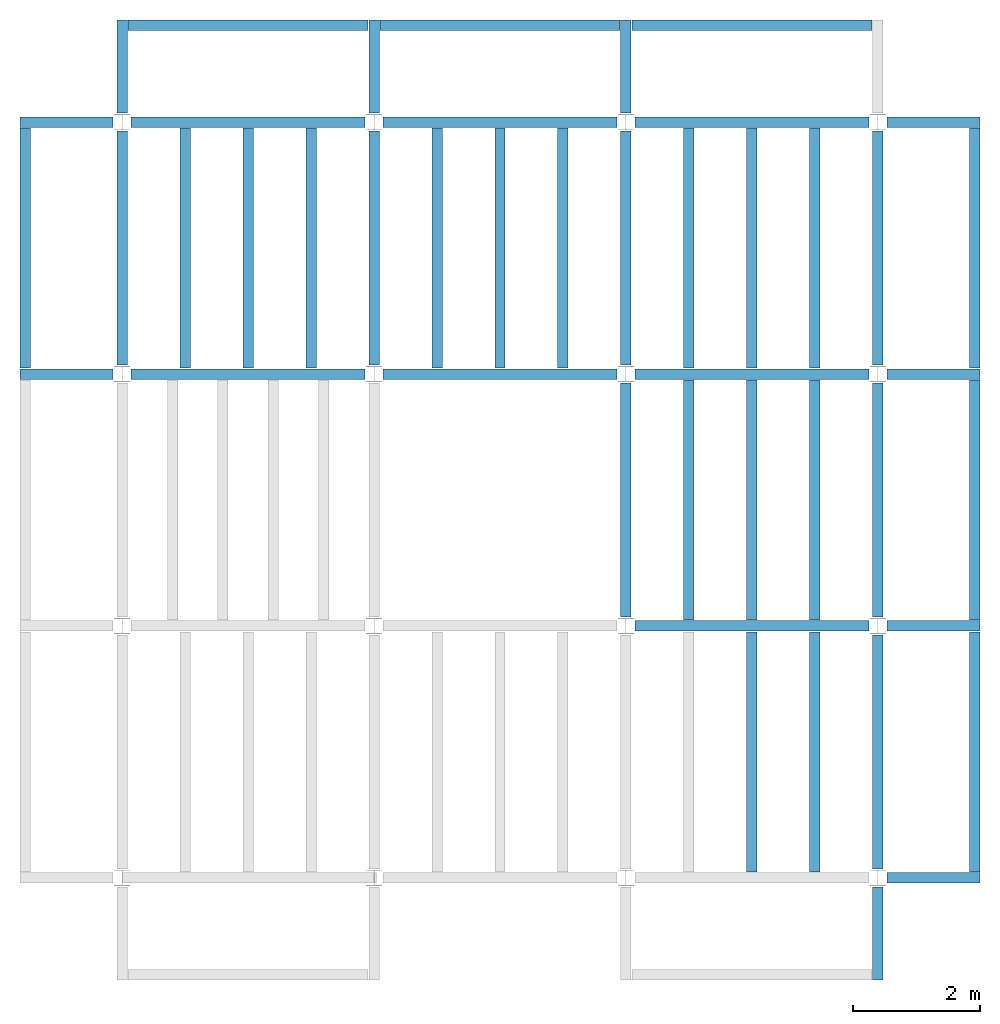
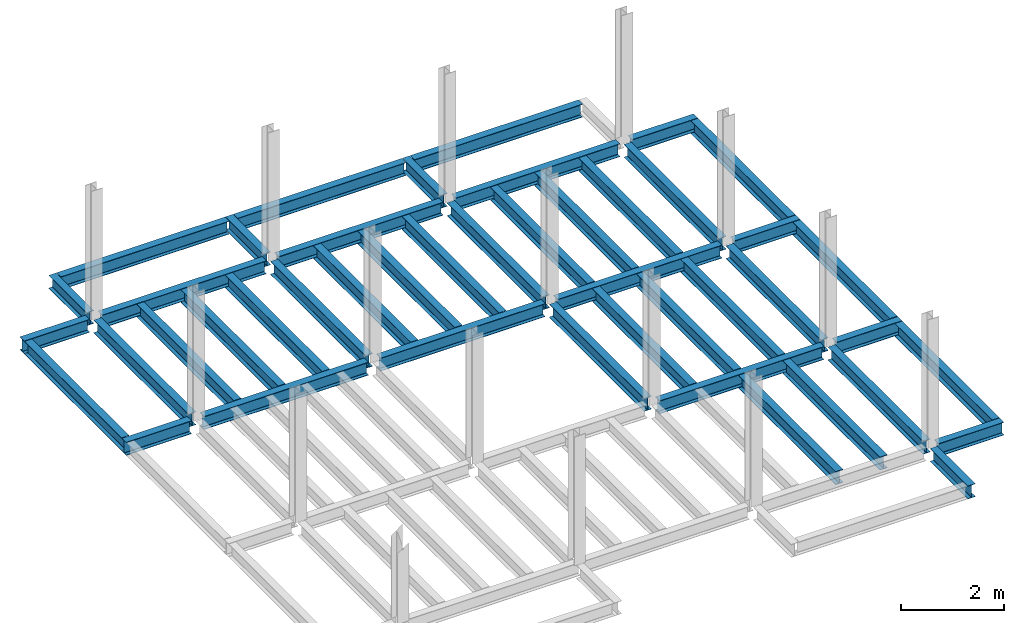
# One storey, part 2 of 3: 45 beams, 5 elements without a shape of their own.
"""IFC4 building model written with IfcOpenShell, lengths in feet."""

from ifc_helpers import new_model, entity, si_unit, converted_unit, derived_unit, direction, frame, origin, place, context, subcontext, project, spatial, line, arc, indexed_curve, outline, extrude, source, transform, mapped, material, type_object, type_shapes, element, aggregate, save


model = new_model("IFC4")

# Units and contexts
model_context = context("Model", 3, precision=0.0001, world=origin(), true_north=direction((6.123233995736766e-17, 1.0)))
plan_context = context("Plan", 3, precision=0.0001, world=origin(), true_north=direction((6.123233995736766e-17, 1.0)))
body_context = subcontext(model_context, "Body", "Model", "MODEL_VIEW")
ifc_project = project(units=[converted_unit("LENGTHUNIT", "FOOT", entity("IfcLengthMeasure", 0.3048), si_unit("LENGTHUNIT", "METRE"), dimensions=[1, 0, 0, 0, 0, 0, 0]), converted_unit("AREAUNIT", "SQUARE FOOT", entity("IfcAreaMeasure", 0.09290304), si_unit("AREAUNIT", "SQUARE_METRE"), dimensions=[2, 0, 0, 0, 0, 0, 0]), converted_unit("PLANEANGLEUNIT", "DEGREE", entity("IfcPlaneAngleMeasure", 0.017453292519943278), si_unit("PLANEANGLEUNIT", "RADIAN"), dimensions=[0, 0, 0, 0, 0, 0, 0]), converted_unit("VOLUMEUNIT", "CUBIC FOOT", entity("IfcVolumeMeasure", 0.028316846592000004), si_unit("VOLUMEUNIT", "CUBIC_METRE"), dimensions=[3, 0, 0, 0, 0, 0, 0]), si_unit("PRESSUREUNIT", "PASCAL"), derived_unit("MASSDENSITYUNIT", [(si_unit("MASSUNIT", "GRAM", prefix="KILO"), 1), (si_unit("LENGTHUNIT", "METRE"), -3)]), derived_unit("VAPORPERMEABILITYUNIT", [(si_unit("LENGTHUNIT", "METRE"), -1), (si_unit("TIMEUNIT", "SECOND"), 1)]), derived_unit("USERDEFINED", [(si_unit("MASSUNIT", "GRAM", prefix="KILO"), 1), (si_unit("LENGTHUNIT", "METRE"), 3), (si_unit("TIMEUNIT", "SECOND"), -3), (si_unit("ELECTRICCURRENTUNIT", "AMPERE"), -2)]), derived_unit("MODULUSOFELASTICITYUNIT", [(si_unit("MASSUNIT", "GRAM", prefix="KILO"), 1), (si_unit("LENGTHUNIT", "METRE"), -1), (si_unit("TIMEUNIT", "SECOND"), -2)]), derived_unit("THERMALEXPANSIONCOEFFICIENTUNIT", [(si_unit("THERMODYNAMICTEMPERATUREUNIT", "KELVIN"), -1)]), derived_unit("SPECIFICHEATCAPACITYUNIT", [(si_unit("TIMEUNIT", "SECOND"), -2), (si_unit("THERMODYNAMICTEMPERATUREUNIT", "KELVIN"), -1), (si_unit("LENGTHUNIT", "METRE"), 2)]), derived_unit("THERMALCONDUCTANCEUNIT", [(si_unit("MASSUNIT", "GRAM", prefix="KILO"), 1), (si_unit("TIMEUNIT", "SECOND"), -3), (si_unit("THERMODYNAMICTEMPERATUREUNIT", "KELVIN"), -1), (si_unit("LENGTHUNIT", "METRE"), 1)])], contexts=[model_context, plan_context])

# Site, building, storey
site_placement = place(None, origin())
site = spatial("IfcSite", under=ifc_project, at=site_placement, CompositionType="ELEMENT")
building_placement = place(site_placement, origin())
building = spatial("IfcBuilding", under=site, at=building_placement, CompositionType="ELEMENT")
storey_placement = place(building_placement, frame((0.0, 0.0, 69.875)))
storey = spatial("IfcBuildingStorey", under=building, at=storey_placement, Name="STR 08", CompositionType="ELEMENT", Elevation=69.875)

# Beams
ifc_material = material(Name="Steel ASTM A992", Category="Metal")
beam_type_1 = type_object("IfcBeamType", Name="W12X26", PredefinedType="JOIST", material=ifc_material)
shared_shape_1 = source(origin(), body_context, "Body", "SweptSolid", [
    extrude(outline(indexed_curve([(-0.27041666666666714, -0.47666666666666574), (-0.27041666666666714, -0.5083333333333351), (0.2704166666666669, -0.5083333333333351), (0.2704166666666669, -0.47666666666666574), (0.03458333333333309, -0.47666666666666574), (0.016905663803669493, -0.46934433619632937), (0.009583333333333202, -0.4516666666666659), (0.0095833333333332, 0.45166666666666705), (0.01690566380366948, 0.4693443361963307), (0.03458333333333325, 0.4766666666666671), (0.2704166666666669, 0.4766666666666671), (0.2704166666666669, 0.5083333333333312), (-0.2704166666666655, 0.5083333333333312), (-0.2704166666666655, 0.4766666666666671), (-0.034583333333333514, 0.47666666666666707), (-0.016905663803669865, 0.46934433619633054), (-0.009583333333333737, 0.45166666666666694), (-0.009583333333333735, -0.4516666666666658), (-0.01690566380367013, -0.4693443361963295), (-0.03458333333333368, -0.47666666666666574)], segments=[line(1, 2, 3, 4, 5), arc(5, 6, 7), line(7, 8), arc(8, 9, 10), line(10, 11, 12, 13, 14, 15), arc(15, 16, 17), line(17, 18), arc(18, 19, 20), line(20, 1)], self_intersect=False)), frame((-6.103346456692914, 0.0, 0.0), z_axis=(-1.0, 0.0, 0.0), x_axis=(0.0, -1.0, 0.0)), (0.0, 0.0, -1.0), 12.083333333333323),
])
type_shapes(beam_type_1, [shared_shape_1])
for number, where, name in (
    (1, (6.561679790026307, 39.0, -0.50833333333334), "W12X26"),
    (2, (6.561679790026288, 26.0, -0.50833333333334), "W12X26"),
):
    element("IfcBeam", number, at=place(storey_placement, frame(where)), inside=storey, type_object=beam_type_1, material=ifc_material, Name=name, ObjectType="W Shapes:W12X26", PredefinedType="JOIST", context=body_context, shape_type="MappedRepresentation", body=[
        mapped(shared_shape_1, transform((0.0, 0.0, 0.0), scale=1.0)),
    ])
beam_1_placement = place(storey_placement, frame((39.0, 6.56167979002612, -0.50833333333334), z_axis=(0.0, 0.0, 1.0), x_axis=(0.0, 1.0, 0.0)))
element("IfcBeam", 3, at=beam_1_placement, inside=storey, type_object=beam_type_1, material=ifc_material, Name="W12X26", ObjectType="W Shapes:W12X26", PredefinedType="JOIST", context=body_context, shape_type="MappedRepresentation", body=[
    mapped(shared_shape_1, transform((0.0, 0.0, 0.0), scale=1.0)),
])
beam_type_2 = type_object("IfcBeamType", Name="W12X26", PredefinedType="JOIST", material=ifc_material)
shared_shape_2 = source(origin(), body_context, "Body", "SweptSolid", [
    extrude(outline(indexed_curve([(-0.27041666666666714, -0.47666666666666574), (-0.27041666666666714, -0.5083333333333351), (0.2704166666666669, -0.5083333333333351), (0.2704166666666669, -0.47666666666666574), (0.03458333333333309, -0.47666666666666574), (0.016905663803669493, -0.46934433619632937), (0.009583333333333202, -0.4516666666666659), (0.0095833333333332, 0.45166666666666705), (0.01690566380366948, 0.4693443361963307), (0.03458333333333325, 0.4766666666666671), (0.2704166666666669, 0.4766666666666671), (0.2704166666666669, 0.5083333333333312), (-0.2704166666666655, 0.5083333333333312), (-0.2704166666666655, 0.4766666666666671), (-0.034583333333333514, 0.47666666666666707), (-0.016905663803669865, 0.46934433619633054), (-0.009583333333333737, 0.45166666666666694), (-0.009583333333333735, -0.4516666666666658), (-0.01690566380367013, -0.4693443361963295), (-0.03458333333333368, -0.47666666666666574)], segments=[line(1, 2, 3, 4, 5), arc(5, 6, 7), line(7, 8), arc(8, 9, 10), line(10, 11, 12, 13, 14, 15), arc(15, 16, 17), line(17, 18), arc(18, 19, 20), line(20, 1)], self_intersect=False)), frame((-6.226706036745409, 0.0, 0.0), z_axis=(-1.0, 0.0, 0.0), x_axis=(0.0, -1.0, 0.0)), (0.0, 0.0, -1.0), 12.08333333333333),
])
type_shapes(beam_type_2, [shared_shape_2])
for number, where, name in (
    (4, (19.685039370078798, 39.0, -0.50833333333334), "W12X26"),
    (5, (19.68503937007878, 26.0, -0.50833333333334), "W12X26"),
):
    element("IfcBeam", number, at=place(storey_placement, frame(where)), inside=storey, type_object=beam_type_2, material=ifc_material, Name=name, ObjectType="W Shapes:W12X26", PredefinedType="JOIST", context=body_context, shape_type="MappedRepresentation", body=[
        mapped(shared_shape_2, transform((0.0, 0.0, 0.0), scale=1.0)),
    ])
for number, where, z_axis, x_axis, name in (
    (6, (39.0, 19.685039370078613, -0.50833333333334), (0.0, 0.0, 1.0), (0.0, 1.0, 0.0), "W12X26"),
    (7, (26.0, 19.685039370078655, -0.50833333333334), (0.0, 0.0, 1.0), (0.0, 1.0, 0.0), "W12X26"),
):
    element("IfcBeam", number, at=place(storey_placement, frame(where, z_axis=z_axis, x_axis=x_axis)), inside=storey, type_object=beam_type_2, material=ifc_material, Name=name, ObjectType="W Shapes:W12X26", PredefinedType="JOIST", context=body_context, shape_type="MappedRepresentation", body=[
        mapped(shared_shape_2, transform((0.0, 0.0, 0.0), scale=1.0)),
    ])

# Assembly, beams
assembly_1_placement = place(storey_placement, origin())
assembly_1 = element("IfcElementAssembly", 8, at=assembly_1_placement, inside=storey, Name="Structural Framing System", ObjectType="Structural Beam System:Structural Framing System", AssemblyPlace="NOTDEFINED", PredefinedType="BEAM_GRID")
beam_type_3 = type_object("IfcBeamType", Name="W12X26", PredefinedType="JOIST", material=ifc_material)
shared_shape_3 = source(origin(), body_context, "Body", "SweptSolid", [
    extrude(outline(indexed_curve([(-0.27041666666666714, -0.47666666666666574), (-0.27041666666666714, -0.5083333333333351), (0.2704166666666669, -0.5083333333333351), (0.2704166666666669, -0.47666666666666574), (0.03458333333333309, -0.47666666666666574), (0.016905663803669493, -0.46934433619632937), (0.009583333333333202, -0.4516666666666659), (0.0095833333333332, 0.45166666666666705), (0.01690566380366948, 0.4693443361963307), (0.03458333333333325, 0.4766666666666671), (0.2704166666666669, 0.4766666666666671), (0.2704166666666669, 0.5083333333333312), (-0.2704166666666655, 0.5083333333333312), (-0.2704166666666655, 0.4766666666666671), (-0.034583333333333514, 0.47666666666666707), (-0.016905663803669865, 0.46934433619633054), (-0.009583333333333737, 0.45166666666666694), (-0.009583333333333735, -0.4516666666666658), (-0.01690566380367013, -0.4693443361963295), (-0.03458333333333368, -0.47666666666666574)], segments=[line(1, 2, 3, 4, 5), arc(5, 6, 7), line(7, 8), arc(8, 9, 10), line(10, 11, 12, 13, 14, 15), arc(15, 16, 17), line(17, 18), arc(18, 19, 20), line(20, 1)], self_intersect=False)), frame((-6.187916666666566, 0.0, 0.0), z_axis=(-1.0, 0.0, 0.0), x_axis=(0.0, -1.0, 0.0)), (0.0, 0.0, -1.0), 12.375833333333075),
])
type_shapes(beam_type_3, [shared_shape_3])
beam_2_placement = place(assembly_1_placement, frame((3.250000000000073, 32.49999999999969, -0.50833333333334), z_axis=(0.0, 0.0, 1.0), x_axis=(0.0, 1.0, 0.0)))
beam_2 = element("IfcBeam", 9, at=beam_2_placement, type_object=beam_type_3, material=ifc_material, Name="W12X26", ObjectType="W Shapes:W12X26", PredefinedType="JOIST", context=body_context, shape_type="MappedRepresentation", body=[
    mapped(shared_shape_3, transform((0.0, 0.0, 0.0), scale=1.0)),
])
beam_3_placement = place(assembly_1_placement, frame((6.500000000000094, 32.49999999999967, -0.50833333333334), z_axis=(0.0, 0.0, 1.0), x_axis=(0.0, 1.0, 0.0)))
beam_3 = element("IfcBeam", 10, at=beam_3_placement, type_object=beam_type_3, material=ifc_material, Name="W12X26", ObjectType="W Shapes:W12X26", PredefinedType="JOIST", context=body_context, shape_type="MappedRepresentation", body=[
    mapped(shared_shape_3, transform((0.0, 0.0, 0.0), scale=1.0)),
])
beam_4_placement = place(assembly_1_placement, frame((9.750000000000115, 32.49999999999966, -0.50833333333334), z_axis=(0.0, 0.0, 1.0), x_axis=(0.0, 1.0, 0.0)))
beam_4 = element("IfcBeam", 11, at=beam_4_placement, type_object=beam_type_3, material=ifc_material, Name="W12X26", ObjectType="W Shapes:W12X26", PredefinedType="JOIST", context=body_context, shape_type="MappedRepresentation", body=[
    mapped(shared_shape_3, transform((0.0, 0.0, 0.0), scale=1.0)),
])
aggregate(assembly_1, [beam_2, beam_3, beam_4])

assembly_2_placement = place(storey_placement, origin())
assembly_2 = element("IfcElementAssembly", 12, at=assembly_2_placement, inside=storey, Name="Structural Framing System", ObjectType="Structural Beam System:Structural Framing System", AssemblyPlace="NOTDEFINED", PredefinedType="BEAM_GRID")
beam_5_placement = place(assembly_2_placement, frame((16.25000000000014, 32.499999999999645, -0.50833333333334), z_axis=(0.0, 0.0, 1.0), x_axis=(0.0, 1.0, 0.0)))
beam_5 = element("IfcBeam", 13, at=beam_5_placement, type_object=beam_type_3, material=ifc_material, Name="W12X26", ObjectType="W Shapes:W12X26", PredefinedType="JOIST", context=body_context, shape_type="MappedRepresentation", body=[
    mapped(shared_shape_3, transform((0.0, 0.0, 0.0), scale=1.0)),
])
beam_6_placement = place(assembly_2_placement, frame((19.50000000000014, 32.49999999999963, -0.50833333333334), z_axis=(0.0, 0.0, 1.0), x_axis=(0.0, 1.0, 0.0)))
beam_6 = element("IfcBeam", 14, at=beam_6_placement, type_object=beam_type_3, material=ifc_material, Name="W12X26", ObjectType="W Shapes:W12X26", PredefinedType="JOIST", context=body_context, shape_type="MappedRepresentation", body=[
    mapped(shared_shape_3, transform((0.0, 0.0, 0.0), scale=1.0)),
])
beam_7_placement = place(assembly_2_placement, frame((22.750000000000142, 32.499999999999616, -0.50833333333334), z_axis=(0.0, 0.0, 1.0), x_axis=(0.0, 1.0, 0.0)))
beam_7 = element("IfcBeam", 15, at=beam_7_placement, type_object=beam_type_3, material=ifc_material, Name="W12X26", ObjectType="W Shapes:W12X26", PredefinedType="JOIST", context=body_context, shape_type="MappedRepresentation", body=[
    mapped(shared_shape_3, transform((0.0, 0.0, 0.0), scale=1.0)),
])
aggregate(assembly_2, [beam_5, beam_6, beam_7])

assembly_3_placement = place(storey_placement, origin())
assembly_3 = element("IfcElementAssembly", 16, at=assembly_3_placement, inside=storey, Name="Structural Framing System", ObjectType="Structural Beam System:Structural Framing System", AssemblyPlace="NOTDEFINED", PredefinedType="BEAM_GRID")
beam_8_placement = place(assembly_3_placement, frame((32.5000000000001, 6.499999999999737, -0.50833333333334), z_axis=(0.0, 0.0, 1.0), x_axis=(0.0, 1.0, 0.0)))
beam_8 = element("IfcBeam", 17, at=beam_8_placement, type_object=beam_type_3, material=ifc_material, Name="W12X26", ObjectType="W Shapes:W12X26", PredefinedType="JOIST", context=body_context, shape_type="MappedRepresentation", body=[
    mapped(shared_shape_3, transform((0.0, 0.0, 0.0), scale=1.0)),
])
beam_9_placement = place(assembly_3_placement, frame((35.7500000000001, 6.499999999999728, -0.50833333333334), z_axis=(0.0, 0.0, 1.0), x_axis=(0.0, 1.0, 0.0)))
beam_9 = element("IfcBeam", 18, at=beam_9_placement, type_object=beam_type_3, material=ifc_material, Name="W12X26", ObjectType="W Shapes:W12X26", PredefinedType="JOIST", context=body_context, shape_type="MappedRepresentation", body=[
    mapped(shared_shape_3, transform((0.0, 0.0, 0.0), scale=1.0)),
])
aggregate(assembly_3, [beam_8, beam_9])

assembly_4_placement = place(storey_placement, origin())
assembly_4 = element("IfcElementAssembly", 19, at=assembly_4_placement, inside=storey, Name="Structural Framing System", ObjectType="Structural Beam System:Structural Framing System", AssemblyPlace="NOTDEFINED", PredefinedType="BEAM_GRID")
beam_10_placement = place(assembly_4_placement, frame((29.25000000000012, 19.499999999999595, -0.50833333333334), z_axis=(0.0, 0.0, 1.0), x_axis=(0.0, 1.0, 0.0)))
beam_10 = element("IfcBeam", 20, at=beam_10_placement, type_object=beam_type_3, material=ifc_material, Name="W12X26", ObjectType="W Shapes:W12X26", PredefinedType="JOIST", context=body_context, shape_type="MappedRepresentation", body=[
    mapped(shared_shape_3, transform((0.0, 0.0, 0.0), scale=1.0)),
])
beam_11_placement = place(assembly_4_placement, frame((32.500000000000114, 19.49999999999958, -0.50833333333334), z_axis=(0.0, 0.0, 1.0), x_axis=(0.0, 1.0, 0.0)))
beam_11 = element("IfcBeam", 21, at=beam_11_placement, type_object=beam_type_3, material=ifc_material, Name="W12X26", ObjectType="W Shapes:W12X26", PredefinedType="JOIST", context=body_context, shape_type="MappedRepresentation", body=[
    mapped(shared_shape_3, transform((0.0, 0.0, 0.0), scale=1.0)),
])
beam_12_placement = place(assembly_4_placement, frame((35.750000000000114, 19.499999999999574, -0.50833333333334), z_axis=(0.0, 0.0, 1.0), x_axis=(0.0, 1.0, 0.0)))
beam_12 = element("IfcBeam", 22, at=beam_12_placement, type_object=beam_type_3, material=ifc_material, Name="W12X26", ObjectType="W Shapes:W12X26", PredefinedType="JOIST", context=body_context, shape_type="MappedRepresentation", body=[
    mapped(shared_shape_3, transform((0.0, 0.0, 0.0), scale=1.0)),
])
aggregate(assembly_4, [beam_10, beam_11, beam_12])

assembly_5_placement = place(storey_placement, origin())
assembly_5 = element("IfcElementAssembly", 23, at=assembly_5_placement, inside=storey, Name="Structural Framing System", ObjectType="Structural Beam System:Structural Framing System", AssemblyPlace="NOTDEFINED", PredefinedType="BEAM_GRID")
beam_13_placement = place(assembly_5_placement, frame((29.250000000000142, 32.4999999999996, -0.50833333333334), z_axis=(0.0, 0.0, 1.0), x_axis=(0.0, 1.0, 0.0)))
beam_13 = element("IfcBeam", 24, at=beam_13_placement, type_object=beam_type_3, material=ifc_material, Name="W12X26", ObjectType="W Shapes:W12X26", PredefinedType="JOIST", context=body_context, shape_type="MappedRepresentation", body=[
    mapped(shared_shape_3, transform((0.0, 0.0, 0.0), scale=1.0)),
])
beam_14_placement = place(assembly_5_placement, frame((32.50000000000014, 32.49999999999959, -0.50833333333334), z_axis=(0.0, 0.0, 1.0), x_axis=(0.0, 1.0, 0.0)))
beam_14 = element("IfcBeam", 25, at=beam_14_placement, type_object=beam_type_3, material=ifc_material, Name="W12X26", ObjectType="W Shapes:W12X26", PredefinedType="JOIST", context=body_context, shape_type="MappedRepresentation", body=[
    mapped(shared_shape_3, transform((0.0, 0.0, 0.0), scale=1.0)),
])
beam_15_placement = place(assembly_5_placement, frame((35.75000000000014, 32.499999999999574, -0.50833333333334), z_axis=(0.0, 0.0, 1.0), x_axis=(0.0, 1.0, 0.0)))
beam_15 = element("IfcBeam", 26, at=beam_15_placement, type_object=beam_type_3, material=ifc_material, Name="W12X26", ObjectType="W Shapes:W12X26", PredefinedType="JOIST", context=body_context, shape_type="MappedRepresentation", body=[
    mapped(shared_shape_3, transform((0.0, 0.0, 0.0), scale=1.0)),
])
aggregate(assembly_5, [beam_13, beam_14, beam_15])

# Beams
for number, where, z_axis, x_axis, name in (
    (27, (-5.0, 32.4999999999997, -0.50833333333334), (0.0, 0.0, 1.0), (0.0, 1.0, 0.0), "W12X26"),
    (28, (44.0, 6.4999999999997, -0.50833333333334), (0.0, 0.0, 1.0), (0.0, 1.0, 0.0), "W12X26"),
    (29, (44.0, 19.499999999999545, -0.50833333333334), (0.0, 0.0, 1.0), (0.0, 1.0, 0.0), "W12X26"),
    (30, (44.0, 32.499999999999545, -0.50833333333334), (0.0, 0.0, 1.0), (0.0, 1.0, 0.0), "W12X26"),
):
    element("IfcBeam", number, at=place(storey_placement, frame(where, z_axis=z_axis, x_axis=x_axis)), inside=storey, type_object=beam_type_3, material=ifc_material, Name=name, ObjectType="W Shapes:W12X26", PredefinedType="JOIST", context=body_context, shape_type="MappedRepresentation", body=[
        mapped(shared_shape_3, transform((0.0, 0.0, 0.0), scale=1.0)),
    ])
beam_16_placement = place(storey_placement, frame((6.5000000000001625, 44.0, -0.50833333333334)))
element("IfcBeam", 31, at=beam_16_placement, inside=storey, type_object=beam_type_3, material=ifc_material, Name="W Shapes:W12X26", ObjectType="W Shapes:W12X26", PredefinedType="JOIST", context=body_context, shape_type="MappedRepresentation", body=[
    mapped(shared_shape_3, transform((0.0, 0.0, 0.0), scale=1.0)),
])
beam_type_4 = type_object("IfcBeamType", Name="W12X26", PredefinedType="JOIST", material=ifc_material)
shared_shape_4 = source(origin(), body_context, "Body", "SweptSolid", [
    extrude(outline(indexed_curve([(-0.27041666666666714, -0.47666666666666574), (-0.27041666666666714, -0.5083333333333351), (0.2704166666666669, -0.5083333333333351), (0.2704166666666669, -0.47666666666666574), (0.03458333333333309, -0.47666666666666574), (0.016905663803669493, -0.46934433619632937), (0.009583333333333202, -0.4516666666666659), (0.0095833333333332, 0.45166666666666705), (0.01690566380366948, 0.4693443361963307), (0.03458333333333325, 0.4766666666666671), (0.2704166666666669, 0.4766666666666671), (0.2704166666666669, 0.5083333333333312), (-0.2704166666666655, 0.5083333333333312), (-0.2704166666666655, 0.4766666666666671), (-0.034583333333333514, 0.47666666666666707), (-0.016905663803669865, 0.46934433619633054), (-0.009583333333333737, 0.45166666666666694), (-0.009583333333333735, -0.4516666666666658), (-0.01690566380367013, -0.4693443361963295), (-0.03458333333333368, -0.47666666666666574)], segments=[line(1, 2, 3, 4, 5), arc(5, 6, 7), line(7, 8), arc(8, 9, 10), line(10, 11, 12, 13, 14, 15), arc(15, 16, 17), line(17, 18), arc(18, 19, 20), line(20, 1)], self_intersect=False)), frame((-6.165026246719308, 0.0, 0.0), z_axis=(-1.0, 0.0, 0.0), x_axis=(0.0, -1.0, 0.0)), (0.0, 0.0, -1.0), 12.08333333333334),
])
type_shapes(beam_type_4, [shared_shape_4])
for number, where, name in (
    (32, (32.6233595800526, 39.0, -0.50833333333334), "W12X26"),
    (33, (32.62335958005258, 26.0, -0.50833333333334), "W12X26"),
    (34, (32.62335958005255, 13.0, -0.50833333333334), "W12X26"),
):
    element("IfcBeam", number, at=place(storey_placement, frame(where)), inside=storey, type_object=beam_type_4, material=ifc_material, Name=name, ObjectType="W Shapes:W12X26", PredefinedType="JOIST", context=body_context, shape_type="MappedRepresentation", body=[
        mapped(shared_shape_4, transform((0.0, 0.0, 0.0), scale=1.0)),
    ])
for number, where, z_axis, x_axis, name in (
    (35, (39.0, 32.62335958005221, -0.50833333333334), (0.0, 0.0, 1.0), (0.0, 1.0, 0.0), "W12X26"),
    (36, (26.0, 32.62335958005225, -0.50833333333334), (0.0, 0.0, 1.0), (0.0, 1.0, 0.0), "W12X26"),
    (37, (13.0, 32.623359580052295, -0.50833333333334), (0.0, 0.0, 1.0), (0.0, 1.0, 0.0), "W12X26"),
    (38, (0.0, 32.62335958005234, -0.50833333333334), (0.0, 0.0, 1.0), (0.0, 1.0, 0.0), "W12X26"),
):
    element("IfcBeam", number, at=place(storey_placement, frame(where, z_axis=z_axis, x_axis=x_axis)), inside=storey, type_object=beam_type_4, material=ifc_material, Name=name, ObjectType="W Shapes:W12X26", PredefinedType="JOIST", context=body_context, shape_type="MappedRepresentation", body=[
        mapped(shared_shape_4, transform((0.0, 0.0, 0.0), scale=1.0)),
    ])
beam_type_5 = type_object("IfcBeamType", Name="W12X26", PredefinedType="JOIST", material=ifc_material)
shared_shape_5 = source(origin(), body_context, "Body", "SweptSolid", [
    extrude(outline(indexed_curve([(0.47666666666666574, -0.2704166666666672), (0.5083333333333351, -0.2704166666666672), (0.5083333333333351, 0.27041666666666686), (0.47666666666666574, 0.27041666666666686), (0.47666666666666574, 0.03458333333333307), (0.46934433619632937, 0.016905663803669473), (0.4516666666666659, 0.00958333333333318), (-0.45166666666666705, 0.00958333333333318), (-0.4693443361963307, 0.01690566380366946), (-0.4766666666666671, 0.03458333333333323), (-0.4766666666666671, 0.27041666666666686), (-0.5083333333333312, 0.27041666666666686), (-0.5083333333333312, -0.27041666666666553), (-0.4766666666666671, -0.27041666666666553), (-0.47666666666666707, -0.034583333333333535), (-0.46934433619633054, -0.016905663803669885), (-0.45166666666666694, -0.00958333333333376), (0.4516666666666658, -0.009583333333333756), (0.4693443361963295, -0.01690566380367015), (0.47666666666666574, -0.0345833333333337)], segments=[line(1, 2, 3, 4, 5), arc(5, 6, 7), line(7, 8), arc(8, 9, 10), line(10, 11, 12, 13, 14, 15), arc(15, 16, 17), line(17, 18), arc(18, 19, 20), line(20, 1)], self_intersect=False)), frame((-2.0416666666666208, 0.0, 0.0), z_axis=(1.0, 0.0, 0.0), x_axis=(0.0, 0.0, -1.0)), (0.0, 0.0, 1.0), 4.812083333333336),
])
type_shapes(beam_type_5, [shared_shape_5])
for number, where, z_axis, x_axis, name in (
    (39, (-2.4999999999998104, 39.0, -0.50833333333334), (0.0, 0.0, 1.0), (-1.0, 0.0, 0.0), "W12X26"),
    (40, (39.0, -2.50000000000058, -0.50833333333334), (0.0, 0.0, 1.0), (0.0, -1.0, 0.0), "W12X26"),
    (41, (-2.4999999999998317, 26.0, -0.50833333333334), (0.0, 0.0, 1.0), (-1.0, 0.0, 0.0), "W12X26"),
):
    element("IfcBeam", number, at=place(storey_placement, frame(where, z_axis=z_axis, x_axis=x_axis)), inside=storey, type_object=beam_type_5, material=ifc_material, Name=name, ObjectType="W Shapes:W12X26", PredefinedType="JOIST", context=body_context, shape_type="MappedRepresentation", body=[
        mapped(shared_shape_5, transform((0.0, 0.0, 0.0), scale=1.0)),
    ])
beam_type_6 = type_object("IfcBeamType", Name="W12X26", PredefinedType="JOIST", material=ifc_material)
shared_shape_6 = source(origin(), body_context, "Body", "SweptSolid", [
    extrude(outline(indexed_curve([(0.47666666666666574, -0.2704166666666672), (0.5083333333333351, -0.2704166666666672), (0.5083333333333351, 0.27041666666666686), (0.47666666666666574, 0.27041666666666686), (0.47666666666666574, 0.03458333333333307), (0.46934433619632937, 0.016905663803669473), (0.4516666666666659, 0.00958333333333318), (-0.45166666666666705, 0.00958333333333318), (-0.4693443361963307, 0.01690566380366946), (-0.4766666666666671, 0.03458333333333323), (-0.4766666666666671, 0.27041666666666686), (-0.5083333333333312, 0.27041666666666686), (-0.5083333333333312, -0.27041666666666553), (-0.4766666666666671, -0.27041666666666553), (-0.47666666666666707, -0.034583333333333535), (-0.46934433619633054, -0.016905663803669885), (-0.45166666666666694, -0.00958333333333376), (0.4516666666666658, -0.009583333333333756), (0.4693443361963295, -0.01690566380367015), (0.47666666666666574, -0.0345833333333337)], segments=[line(1, 2, 3, 4, 5), arc(5, 6, 7), line(7, 8), arc(8, 9, 10), line(10, 11, 12, 13, 14, 15), arc(15, 16, 17), line(17, 18), arc(18, 19, 20), line(20, 1)], self_intersect=False)), frame((-2.77041666666672, 0.0, 0.0), z_axis=(1.0, 0.0, 0.0), x_axis=(0.0, 0.0, -1.0)), (0.0, 0.0, 1.0), 4.812083333333389),
])
type_shapes(beam_type_6, [shared_shape_6])
for number, where, z_axis, x_axis, name in (
    (42, (41.50000000000013, 26.0, -0.50833333333334), (0.0, 0.0, 1.0), (-1.0, 0.0, 0.0), "W12X26"),
    (43, (41.50000000000011, 13.0, -0.50833333333334), (0.0, 0.0, 1.0), (-1.0, 0.0, 0.0), "W12X26"),
    (44, (41.500000000000085, 0.0, -0.50833333333334), (0.0, 0.0, 1.0), (-1.0, 0.0, 0.0), "W12X26"),
    (45, (13.0, 41.49999999999965, -0.50833333333334), (0.0, 0.0, 1.0), (0.0, -1.0, 0.0), "W12X26"),
    (46, (0.0, 41.499999999999694, -0.50833333333334), (0.0, 0.0, 1.0), (0.0, -1.0, 0.0), "W12X26"),
    (47, (41.50000000000015, 39.0, -0.50833333333334), (0.0, 0.0, 1.0), (-1.0, 0.0, 0.0), "W12X26"),
):
    element("IfcBeam", number, at=place(storey_placement, frame(where, z_axis=z_axis, x_axis=x_axis)), inside=storey, type_object=beam_type_6, material=ifc_material, Name=name, ObjectType="W Shapes:W12X26", PredefinedType="JOIST", context=body_context, shape_type="MappedRepresentation", body=[
        mapped(shared_shape_6, transform((0.0, 0.0, 0.0), scale=1.0)),
    ])
beam_type_7 = type_object("IfcBeamType", Name="W12X26", PredefinedType="JOIST", material=ifc_material)
shared_shape_7 = source(origin(), body_context, "Body", "SweptSolid", [
    extrude(outline(indexed_curve([(0.47666666666666574, -0.2704166666666672), (0.5083333333333351, -0.2704166666666672), (0.5083333333333351, 0.27041666666666686), (0.47666666666666574, 0.27041666666666686), (0.47666666666666574, 0.03458333333333307), (0.46934433619632937, 0.016905663803669473), (0.4516666666666659, 0.00958333333333318), (-0.45166666666666705, 0.00958333333333318), (-0.4693443361963307, 0.01690566380366946), (-0.4766666666666671, 0.03458333333333323), (-0.4766666666666671, 0.27041666666666686), (-0.5083333333333312, 0.27041666666666686), (-0.5083333333333312, -0.27041666666666553), (-0.4766666666666671, -0.27041666666666553), (-0.47666666666666707, -0.034583333333333535), (-0.46934433619633054, -0.016905663803669885), (-0.45166666666666694, -0.00958333333333376), (0.4516666666666658, -0.009583333333333756), (0.4693443361963295, -0.01690566380367015), (0.47666666666666574, -0.0345833333333337)], segments=[line(1, 2, 3, 4, 5), arc(5, 6, 7), line(7, 8), arc(8, 9, 10), line(10, 11, 12, 13, 14, 15), arc(15, 16, 17), line(17, 18), arc(18, 19, 20), line(20, 1)], self_intersect=False)), frame((-6.187916666666685, 0.0, 0.0), z_axis=(1.0, 0.0, 0.0), x_axis=(0.0, 0.0, -1.0)), (0.0, 0.0, 1.0), 12.375833333333318),
])
type_shapes(beam_type_7, [shared_shape_7])
beam_17_placement = place(storey_placement, frame((19.500000000000142, 44.0, -0.50833333333334), z_axis=(0.0, 0.0, 1.0), x_axis=(-1.0, 0.0, 0.0)))
element("IfcBeam", 48, at=beam_17_placement, inside=storey, type_object=beam_type_7, material=ifc_material, Name="W Shapes:W12X26", ObjectType="W Shapes:W12X26", PredefinedType="JOIST", context=body_context, shape_type="MappedRepresentation", body=[
    mapped(shared_shape_7, transform((0.0, 0.0, 0.0), scale=1.0)),
])
beam_type_8 = type_object("IfcBeamType", Name="W12X26", PredefinedType="JOIST", material=ifc_material)
shared_shape_8 = source(origin(), body_context, "Body", "SweptSolid", [
    extrude(outline(indexed_curve([(-0.2704166666666694, -0.5083333333333258), (0.27041666666666586, -0.5083333333333258), (0.2704166666666623, -0.47666666666665947), (0.034583333333333854, -0.4766666666666737), (0.016905663803669313, -0.469344336196329), (0.009583333333335275, -0.451666666666668), (0.009583333333335275, 0.451666666666668), (0.016905663803669313, 0.469344336196329), (0.034583333333333854, 0.4766666666666737), (0.2704166666666694, 0.4766666666666737), (0.27041666666666586, 0.50833333333334), (-0.27041666666666586, 0.50833333333334), (-0.27041666666666586, 0.4766666666666737), (-0.0345833333333303, 0.4766666666666737), (-0.01690566380366576, 0.469344336196329), (-0.009583333333331723, 0.451666666666668), (-0.009583333333331723, -0.451666666666668), (-0.01690566380366576, -0.469344336196329), (-0.034583333333333854, -0.47666666666665947), (-0.27041666666666586, -0.47666666666665947)], segments=[line(1, 2, 3, 4), arc(4, 5, 6), line(6, 7), arc(7, 8, 9), line(9, 10, 11, 12, 13, 14), arc(14, 15, 16), line(16, 17), arc(17, 18, 19), line(19, 20, 1)], self_intersect=False)), frame((26.0, 44.27041666666632, 69.36666666666665), z_axis=(0.0, -1.0, 0.0), x_axis=(-1.0, 0.0, 0.0)), (0.0, 0.0, 1.0), 4.812083333333393),
])
type_shapes(beam_type_8, [shared_shape_8])
beam_18_placement = place(storey_placement, frame((0.0, 0.0, -69.875)))
element("IfcBeam", 49, at=beam_18_placement, inside=storey, type_object=beam_type_8, material=ifc_material, Name="W12X26", ObjectType="W Shapes:W12X26", PredefinedType="JOIST", context=body_context, shape_type="MappedRepresentation", body=[
    mapped(shared_shape_8, transform((0.0, 0.0, 0.0), scale=1.0)),
])
beam_type_9 = type_object("IfcBeamType", Name="W12X26", PredefinedType="JOIST", material=ifc_material)
shared_shape_9 = source(origin(), body_context, "Body", "SweptSolid", [
    extrude(outline(indexed_curve([(-0.5083333333333258, -0.2704166666666694), (-0.47666666666665947, -0.2704166666666694), (-0.4766666666666737, -0.03458333333333741), (-0.469344336196329, -0.01690566380367642), (-0.451666666666668, -0.009583333333338828), (0.451666666666668, -0.009583333333338828), (0.469344336196329, -0.01690566380367642), (0.4766666666666737, -0.03458333333333741), (0.4766666666666737, -0.2704166666666694), (0.50833333333334, -0.2704166666666694), (0.50833333333334, 0.2704166666666623), (0.4766666666666737, 0.2704166666666623), (0.4766666666666737, 0.0345833333333303), (0.469344336196329, 0.016905663803669313), (0.451666666666668, 0.009583333333331723), (-0.451666666666668, 0.009583333333331723), (-0.469344336196329, 0.016905663803669313), (-0.47666666666665947, 0.0345833333333303), (-0.47666666666665947, 0.2704166666666623), (-0.5083333333333258, 0.2704166666666623)], segments=[line(1, 2, 3), arc(3, 4, 5), line(5, 6), arc(6, 7, 8), line(8, 9, 10, 11, 12, 13), arc(13, 14, 15), line(15, 16), arc(16, 17, 18), line(18, 19, 20, 1)], self_intersect=False)), frame((26.312083333333604, 44.0, 69.36666666666665), z_axis=(1.0, 0.0, 0.0), x_axis=(0.0, 0.0, -1.0)), (0.0, 0.0, 1.0), 12.375833333333079),
])
type_shapes(beam_type_9, [shared_shape_9])
beam_19_placement = place(storey_placement, frame((0.0, 0.0, -69.875)))
element("IfcBeam", 50, at=beam_19_placement, inside=storey, type_object=beam_type_9, material=ifc_material, Name="W Shapes:W12X26", ObjectType="W Shapes:W12X26", PredefinedType="JOIST", context=body_context, shape_type="MappedRepresentation", body=[
    mapped(shared_shape_9, transform((0.0, 0.0, 0.0), scale=1.0)),
])

save(model, "model.ifc")
